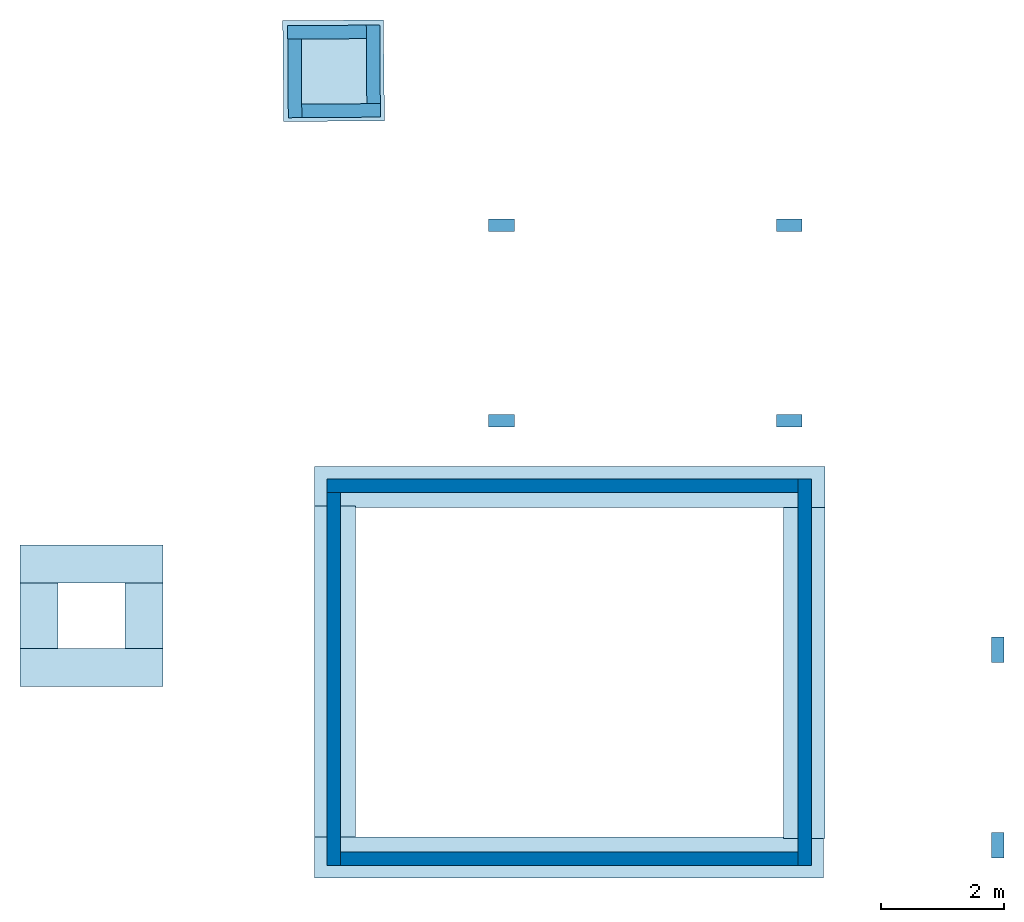
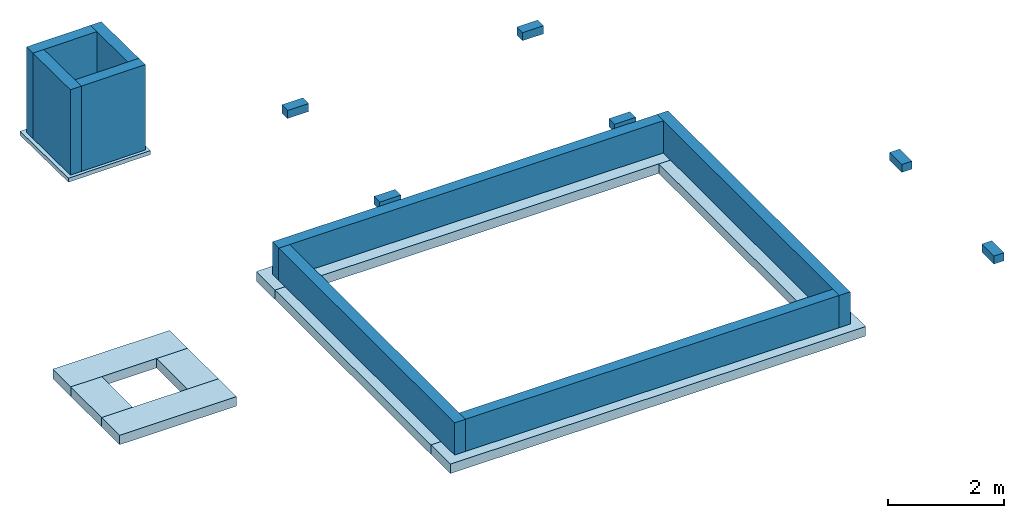
"""IFC4X3_ADD2 building model written with IfcOpenShell, lengths in millimetres."""

import ifcopenshell
import ifcopenshell.guid

model = None  # the IFC model being written
_history = None  # IfcOwnerHistory: only IFC2X3 demands one
_inside = {}  # id of a spatial element -> (the spatial element, [elements in it])
_under = {}  # id of a project, library or spatial element -> (it, [spatial elements below it])
_declared = {}  # id of a project -> (the project, [libraries it declares])
_typed = {}  # id of a type object -> (the type object, [elements of that type])
_made_of = {}  # id of a material, layer set ... -> (it, [elements and type objects made of it])


def new_model(schema):
    """Start an empty IFC model of exactly this schema.

    Asked for "IFC4X3", IfcOpenShell would pick the latest addendum, in which some entities
    have other attributes; the version numbers below select the first issue.
    IFC2X3 requires an IfcOwnerHistory on every rooted entity: one is made here for all.
    """
    global model, _history
    if schema == "IFC4X3":
        model = ifcopenshell.file(schema_version=(4, 3, 0, 0))
    else:
        model = ifcopenshell.file(schema=schema)
    _inside.clear()
    _under.clear()
    _declared.clear()
    _typed.clear()
    _made_of.clear()
    _history = None
    if model.schema == "IFC2X3":
        org = make("IfcOrganization", Name="unknown")
        user = make(
            "IfcPersonAndOrganization",
            ThePerson=make("IfcPerson", FamilyName="unknown"),
            TheOrganization=org,
        )
        app = make(
            "IfcApplication",
            ApplicationDeveloper=org,
            Version="unknown",
            ApplicationFullName="unknown",
            ApplicationIdentifier="unknown",
        )
        _history = make(
            "IfcOwnerHistory",
            OwningUser=user,
            OwningApplication=app,
            ChangeAction="ADDED",
            CreationDate=0,
        )
    return model


def make(cls, **values):
    """One entity of the class cls with the attributes given. An attribute that is None is left unset."""
    return model.create_entity(
        cls, **{name: value for name, value in values.items() if value is not None}
    )


def entity(cls, *values):
    """Any entity or typed value of the class cls, its attributes in the order of the schema. None: left unset."""
    e = model.create_entity(cls)
    for i, value in enumerate(values):
        if value is not None:
            e[i] = value
    return e


def rooted(cls, **values):
    """An entity with a GlobalId (a new one), such as an element, a storey or a relation."""
    return make(cls, GlobalId=ifcopenshell.guid.new(), OwnerHistory=_history, **values)


def si_unit(unit_type, name, prefix=None):
    """IfcSIUnit, for example si_unit("LENGTHUNIT", "METRE", prefix="MILLI")."""
    return make("IfcSIUnit", UnitType=unit_type, Prefix=prefix, Name=name)


def converted_unit(unit_type, name, factor, base, dimensions=None, offset=None):
    """IfcConversionBasedUnit, such as the inch: factor (a typed value) times the base unit."""
    return make(
        "IfcConversionBasedUnit"
        if offset is None
        else "IfcConversionBasedUnitWithOffset",
        ConversionOffset=offset,
        Dimensions=None
        if dimensions is None
        else entity("IfcDimensionalExponents", *dimensions),
        UnitType=unit_type,
        Name=name,
        ConversionFactor=make(
            "IfcMeasureWithUnit", ValueComponent=factor, UnitComponent=base
        ),
    )


def assignment(units):
    """IfcUnitAssignment: the units of a project."""
    return None if units is None else make("IfcUnitAssignment", Units=units)


def point(xyz):
    """IfcCartesianPoint."""
    return None if xyz is None else make("IfcCartesianPoint", Coordinates=xyz)


def direction(xyz):
    """IfcDirection."""
    return None if xyz is None else make("IfcDirection", DirectionRatios=xyz)


def frame(location, z_axis=None, x_axis=None):
    """IfcAxis2Placement3D, a coordinate frame: its origin and axes. An axis left out is left unset."""
    return make(
        "IfcAxis2Placement3D",
        Location=point(location),
        Axis=direction(z_axis),
        RefDirection=direction(x_axis),
    )


def frame_2d(location, x_axis=None):
    """IfcAxis2Placement2D, a coordinate frame in the plane: its origin and x axis."""
    return make(
        "IfcAxis2Placement2D", Location=point(location), RefDirection=direction(x_axis)
    )


def origin_with_axes():
    """The frame at (0, 0, 0) with the z axis (0, 0, 1) and the x axis (1, 0, 0) written out."""
    return frame((0.0, 0.0, 0.0), z_axis=(0.0, 0.0, 1.0), x_axis=(1.0, 0.0, 0.0))


def origin_2d_with_axis():
    """The frame at (0, 0) in the plane with the x axis (1, 0) written out."""
    return frame_2d((0.0, 0.0), x_axis=(1.0, 0.0))


def place(relative_to, where):
    """IfcLocalPlacement: puts the frame where relative to a parent placement (None: the world)."""
    return make(
        "IfcLocalPlacement", PlacementRelTo=relative_to, RelativePlacement=where
    )


def context(
    kind, dimensions, precision=None, world=None, true_north=None, identifier=None
):
    """IfcGeometricRepresentationContext, for example the 3D "Model" context."""
    return make(
        "IfcGeometricRepresentationContext",
        ContextIdentifier=identifier,
        ContextType=kind,
        CoordinateSpaceDimension=dimensions,
        Precision=precision,
        WorldCoordinateSystem=world,
        TrueNorth=true_north,
    )


def subcontext(parent, identifier, kind, view, scale=None):
    """IfcGeometricRepresentationSubContext, for example "Body" below "Model"."""
    return make(
        "IfcGeometricRepresentationSubContext",
        ContextIdentifier=identifier,
        ContextType=kind,
        ParentContext=parent,
        TargetScale=scale,
        TargetView=view,
    )


def project(units=None, contexts=None):
    """IfcProject with its units and contexts."""
    return rooted(
        "IfcProject",
        Name="project",
        RepresentationContexts=contexts,
        UnitsInContext=assignment(units),
    )


def spatial(cls, under=None, at=None, **own):
    """A site, building, storey or space (cls), placed at a placement, below another one or the project."""
    s = rooted(cls, ObjectPlacement=at, **own)
    if under is not None:
        _under.setdefault(under.id(), (under, []))[1].append(s)
    return s


def point_list(points):
    """IfcCartesianPointList2D or 3D."""
    cls = (
        "IfcCartesianPointList2D" if len(points[0]) == 2 else "IfcCartesianPointList3D"
    )
    return make(cls, CoordList=points)


def indexed_curve(points, segments=None, self_intersect=None):
    """IfcIndexedPolyCurve: lines and arcs through numbered points (the first is 1)."""
    return make(
        "IfcIndexedPolyCurve",
        Points=point_list(points),
        Segments=segments,
        SelfIntersect=self_intersect,
    )


def outline(outer, holes=None, kind="AREA"):
    """IfcArbitraryClosedProfileDef: a profile drawn as a closed curve; with holes, ...WithVoids."""
    if holes is None:
        return make("IfcArbitraryClosedProfileDef", ProfileType=kind, OuterCurve=outer)
    return make(
        "IfcArbitraryProfileDefWithVoids",
        ProfileType=kind,
        OuterCurve=outer,
        InnerCurves=holes,
    )


def extrude(swept, where, along, depth):
    """IfcExtrudedAreaSolid: the profile swept, set in the frame where, extruded along a direction by depth."""
    return make(
        "IfcExtrudedAreaSolid",
        SweptArea=swept,
        Position=where,
        ExtrudedDirection=direction(along),
        Depth=depth,
    )


def shape(context_of_items, identifier, shape_type, items):
    """IfcShapeRepresentation: the items that make up one representation, for example the "Body"."""
    return make(
        "IfcShapeRepresentation",
        ContextOfItems=context_of_items,
        RepresentationIdentifier=identifier,
        RepresentationType=shape_type,
        Items=items,
    )


def material(Name=None, Category=None):
    """IfcMaterial."""
    return make("IfcMaterial", Name=Name, Category=Category)


def layer(
    of_material, thickness, ventilated=None, Name=None, Category=None, Priority=None
):
    """IfcMaterialLayer: one layer of a wall or slab, of a material (None: an air gap)."""
    return make(
        "IfcMaterialLayer",
        Material=of_material,
        LayerThickness=thickness,
        IsVentilated=ventilated,
        Name=Name,
        Category=Category,
        Priority=Priority,
    )


def layer_set(layers, Name=None):
    """IfcMaterialLayerSet."""
    return make("IfcMaterialLayerSet", MaterialLayers=layers, LayerSetName=Name)


def layer_usage(for_layer_set, set_direction, sense, offset, extent=None):
    """IfcMaterialLayerSetUsage: how a layer set lies in its element."""
    return make(
        "IfcMaterialLayerSetUsage",
        ForLayerSet=for_layer_set,
        LayerSetDirection=set_direction,
        DirectionSense=sense,
        OffsetFromReferenceLine=offset,
        ReferenceExtent=extent,
    )


def made_of(thing, what):
    """Note that an element or type object is made of a material, layer set ...; save() writes the relation."""
    if what is not None:
        _made_of.setdefault(what.id(), (what, []))[1].append(thing)
    return thing


def type_object(cls, material=None, **own):
    """A type object (cls), such as IfcWallType, which elements share."""
    return made_of(rooted(cls, **own), material)


def element(
    cls,
    number,
    at=None,
    inside=None,
    cuts=None,
    type_object=None,
    material=None,
    context=None,
    identifier="Body",
    shape_type=None,
    held_by="IfcProductDefinitionShape",
    body=None,
    shapes=None,
    **own,
):
    """One element of the class cls, such as IfcWall. Its Tag is "e" and its number.

    at: its placement. inside: the storey or other place that contains it. cuts: it is an
    opening in that element (IfcRelVoidsElement). A single representation is given by context,
    identifier, shape_type and body (its items); several are given by shapes. held_by: the class
    of the entity that holds the representations. save() writes the other relations.
    """
    e = rooted(cls, Tag="e%d" % number, ObjectPlacement=at, **own)
    if body is not None:
        shapes = [shape(context, identifier, shape_type, body)]
    if shapes is not None:
        e.Representation = make(held_by, Representations=shapes)
    if inside is not None:
        _inside.setdefault(inside.id(), (inside, []))[1].append(e)
    if cuts is not None:
        rooted(
            "IfcRelVoidsElement", RelatingBuildingElement=cuts, RelatedOpeningElement=e
        )
    if type_object is not None:
        _typed.setdefault(type_object.id(), (type_object, []))[1].append(e)
    return made_of(e, material)


def aggregate(whole, parts):
    """IfcRelAggregates: a whole, such as a stair, and the parts it consists of."""
    return rooted("IfcRelAggregates", RelatingObject=whole, RelatedObjects=parts)


def save(model, path):
    """Write the relations noted so far, then the file.

    IfcRelAggregates (storeys below a building ...), IfcRelContainedInSpatialStructure (elements
    in a storey), IfcRelDefinesByType, IfcRelAssociatesMaterial and IfcRelDeclares: one each for
    every whole, place, type object, material and project.
    """
    for whole, parts in _under.values():
        aggregate(whole, parts)
    for where, things in _inside.values():
        rooted(
            "IfcRelContainedInSpatialStructure",
            RelatedElements=things,
            RelatingStructure=where,
        )
    for kind, things in _typed.values():
        rooted("IfcRelDefinesByType", RelatedObjects=things, RelatingType=kind)
    for what, things in _made_of.values():
        rooted("IfcRelAssociatesMaterial", RelatedObjects=things, RelatingMaterial=what)
    for by, libraries in _declared.values():
        rooted("IfcRelDeclares", RelatingContext=by, RelatedDefinitions=libraries)
    model.write(path)


model = new_model("IFC4X3_ADD2")

# Units and contexts
model_context = context("Model", 3, precision=1e-05, world=origin_with_axes(), true_north=direction((0.0, 1.0, 0.0)))
plan_context = context("Plan", 2, precision=1e-05, world=origin_2d_with_axis(), true_north=direction((0.0, 1.0)))
body_context = subcontext(model_context, "Body", "Model", "MODEL_VIEW")
ifc_project = project(units=[si_unit("AREAUNIT", "SQUARE_METRE"), si_unit("VOLUMEUNIT", "CUBIC_METRE"), si_unit("LENGTHUNIT", "METRE", prefix="MILLI"), converted_unit("PLANEANGLEUNIT", "degree", entity("IfcReal", 0.0174532925199433), si_unit("PLANEANGLEUNIT", "RADIAN"), dimensions=[0, 0, 0, 0, 0, 0, 0])], contexts=[model_context, plan_context])

# Site, building, storeys
site_placement = place(None, origin_with_axes())
site = spatial("IfcSite", under=ifc_project, at=site_placement)
building_placement = place(site_placement, origin_with_axes())
building = spatial("IfcBuilding", under=site, at=building_placement, Name="Simple 1Bed House")
storey_1_placement = place(building_placement, origin_with_axes())
storey_1 = spatial("IfcBuildingStorey", under=building, at=storey_1_placement, Name="Building")
storey_2_placement = place(storey_1_placement, origin_with_axes())
storey_2 = spatial("IfcBuildingStorey", under=storey_1, at=storey_2_placement, Name="Foundation")

# Footings
ifc_material_1 = material(Name="25 MPa wooden float", Category="Concrete")
ifc_layer_1 = layer(ifc_material_1, 200.0)
ifc_layer_set_1 = layer_set([ifc_layer_1], Name="concrete")
ifc_layer_usage_1 = layer_usage(ifc_layer_set_1, "AXIS3", "POSITIVE", 0.0)
footing_type = type_object("IfcFootingType", Name="Foundation 600x280", PredefinedType="STRIP_FOOTING", material=ifc_layer_set_1)
footing_1_placement = place(storey_2_placement, frame((8640.92254638672, 6085.35528182983, -879.999995231629), z_axis=(0.0, 0.0, 1.0), x_axis=(-0.999999999999924, -3.89414367418765e-07, 0.0)))
element("IfcFooting", 1, at=footing_1_placement, inside=storey_2, type_object=footing_type, material=ifc_layer_usage_1, Name="600x280 Concrete foundation", context=body_context, shape_type="SolidModel", body=[
    extrude(outline(indexed_curve([(8369.2353515625, -445.002777099609), (59.7821655273438, -445.002777099609), (59.7821807861328, 224.999267578125), (8369.2353515625, 224.999252319336), (8369.2353515625, -445.002777099609)])), None, (0.0, 0.0, 1.0), 200.0),
])
ifc_layer_usage_2 = layer_usage(ifc_layer_set_1, "AXIS3", "POSITIVE", 0.0)
footing_2_placement = place(storey_2_placement, frame((716.687917709351, 6435.35232543945, -879.999995231628), z_axis=(0.0, 0.0, 1.0), x_axis=(-0.999999999999924, -3.89414367418765e-07, 0.0)))
element("IfcFooting", 2, at=footing_2_placement, inside=storey_2, type_object=footing_type, material=ifc_layer_usage_2, Name="600x280 Concrete foundation", context=body_context, shape_type="SolidModel", body=[
    extrude(outline(indexed_curve([(445.001586914062, 5934.35107421875), (445.001525878906, 549.999328613281), (-224.999923706055, 549.999328613281), (-224.999786376953, 5934.35107421875), (445.001586914062, 5934.35107421875)])), None, (0.0, 0.0, 1.0), 200.0),
])
ifc_layer_usage_3 = layer_usage(ifc_layer_set_1, "AXIS3", "POSITIVE", 0.0)
footing_3_placement = place(storey_2_placement, frame((8640.92445373535, 56.000292301178, -879.999995231628), z_axis=(0.0, 0.0, 1.0), x_axis=(-0.999999999999924, -3.89414367418765e-07, 0.0)))
element("IfcFooting", 3, at=footing_3_placement, inside=storey_2, type_object=footing_type, material=ifc_layer_usage_3, Name="600x280 Concrete foundation", context=body_context, shape_type="SolidModel", body=[
    extrude(outline(indexed_curve([(84.7802658081055, -445.002777099609), (84.7802810668945, 224.999252319336), (8369.234375, 224.999252319336), (8369.234375, -445.002777099609), (84.7802658081055, -445.002777099609)])), None, (0.0, 0.0, 1.0), 200.0),
])
ifc_layer_usage_4 = layer_usage(ifc_layer_set_1, "AXIS2", "POSITIVE", 0.0)
footing_4_placement = place(storey_2_placement, frame((3104.93040084839, 10359.0650558472, -769.999980926514), z_axis=(0.0, 0.0, 1.0), x_axis=(0.999999999999936, -3.57627868652321e-07, 0.0)))
element("IfcFooting", 4, at=footing_4_placement, inside=storey_2, type_object=footing_type, material=ifc_layer_usage_4, Name="Footing", context=body_context, shape_type="SweptSolid", body=[
    extrude(outline(indexed_curve([(0.0, 0.0), (0.0, 200.0), (420.001035813916, 200.0), (420.001035813916, 0.0), (0.0, 0.0)], self_intersect=False)), origin_with_axes(), (0.0, 0.0, 1.0), 170.000001788139),
])
ifc_layer_usage_5 = layer_usage(ifc_layer_set_1, "AXIS2", "POSITIVE", 0.0)
footing_5_placement = place(storey_2_placement, frame((11500.0066757202, 3335.84809303284, -516.634404659271), z_axis=(0.0, 0.0, 1.0), x_axis=(3.13916473260163e-07, 0.999999999999951, 0.0)))
element("IfcFooting", 5, at=footing_5_placement, inside=storey_2, type_object=footing_type, material=ifc_layer_usage_5, Name="Footing", context=body_context, shape_type="SweptSolid", body=[
    extrude(outline(indexed_curve([(0.0, 0.0), (0.0, 200.0), (420.001035813916, 200.0), (420.001035813916, 0.0), (0.0, 0.0)], self_intersect=False)), origin_with_axes(), (0.0, 0.0, 1.0), 170.000001788139),
])
ifc_layer_usage_6 = layer_usage(ifc_layer_set_1, "AXIS2", "POSITIVE", 0.0)
footing_6_placement = place(storey_2_placement, frame((11500.0076293945, 150.846943259239, -516.634404659271), z_axis=(0.0, 0.0, 1.0), x_axis=(3.13916473260163e-07, 0.999999999999951, 0.0)))
element("IfcFooting", 6, at=footing_6_placement, inside=storey_2, type_object=footing_type, material=ifc_layer_usage_6, Name="Footing", context=body_context, shape_type="SweptSolid", body=[
    extrude(outline(indexed_curve([(0.0, 0.0), (0.0, 200.0), (420.001035813916, 200.0), (420.001035813916, 0.0), (0.0, 0.0)], self_intersect=False)), origin_with_axes(), (0.0, 0.0, 1.0), 170.000001788139),
])
ifc_layer_usage_7 = layer_usage(ifc_layer_set_1, "AXIS2", "POSITIVE", 0.0)
footing_7_placement = place(storey_2_placement, frame((7791.34273529053, 10359.0650558472, -769.999921321869), z_axis=(0.0, 0.0, 1.0), x_axis=(0.999999999999936, -3.57627868652321e-07, 0.0)))
element("IfcFooting", 7, at=footing_7_placement, inside=storey_2, type_object=footing_type, material=ifc_layer_usage_7, Name="Footing", context=body_context, shape_type="SweptSolid", body=[
    extrude(outline(indexed_curve([(0.0, 0.0), (0.0, 200.0), (420.001035813916, 200.0), (420.001035813916, 0.0), (0.0, 0.0)], self_intersect=False)), origin_with_axes(), (0.0, 0.0, 1.0), 170.000001788139),
])
ifc_layer_usage_8 = layer_usage(ifc_layer_set_1, "AXIS3", "POSITIVE", 0.0)
footing_8_placement = place(storey_2_placement, frame((8356.14013671875, 6435.35232543945, -879.999995231628), z_axis=(0.0, 0.0, 1.0), x_axis=(-0.999999999999924, -3.89414367418765e-07, 0.0)))
element("IfcFooting", 8, at=footing_8_placement, inside=storey_2, type_object=footing_type, material=ifc_layer_usage_8, Name="600x280 Concrete foundation", context=body_context, shape_type="SolidModel", body=[
    extrude(outline(indexed_curve([(445.001617431641, 5959.3486328125), (445.001525878906, 574.999267578125), (-224.999908447266, 574.999267578125), (-224.999771118164, 5959.3486328125), (445.001617431641, 5959.3486328125)])), None, (0.0, 0.0, 1.0), 200.0),
])
ifc_layer_usage_9 = layer_usage(ifc_layer_set_1, "AXIS3", "POSITIVE", 0.0)
footing_9_placement = place(storey_2_placement, frame((3718.46485137939, 4830.3394317627, -481.297969818115), z_axis=(0.0, 0.0, 1.0), x_axis=(-0.999999999999924, -3.89414367418765e-07, 0.0)))
element("IfcFooting", 9, at=footing_9_placement, inside=storey_2, type_object=footing_type, material=ifc_layer_usage_9, Name="600x280 Concrete foundation", context=body_context, shape_type="SweptSolid", body=[
    extrude(outline(indexed_curve([(8245.234375, 199.99934387207), (5915.3359375, 199.996994018555), (5915.3359375, -420.005126953125), (8245.234375, -420.002807617188), (8245.234375, 199.99934387207)])), None, (0.0, 0.0, 1.0), 200.0),
])
ifc_layer_usage_10 = layer_usage(ifc_layer_set_1, "AXIS3", "POSITIVE", 0.0)
footing_10_placement = place(storey_2_placement, frame((3718.46485137939, 3145.9321975708, -481.297969818115), z_axis=(0.0, 0.0, 1.0), x_axis=(-0.999999999999924, -3.89414367418765e-07, 0.0)))
element("IfcFooting", 10, at=footing_10_placement, inside=storey_2, type_object=footing_type, material=ifc_layer_usage_10, Name="600x280 Concrete foundation", context=body_context, shape_type="SweptSolid", body=[
    extrude(outline(indexed_curve([(8245.234375, 199.99934387207), (5915.3359375, 199.996994018555), (5915.3359375, -420.005126953125), (8245.234375, -420.002807617188), (8245.234375, 199.99934387207)])), None, (0.0, 0.0, 1.0), 200.0),
])
ifc_layer_usage_11 = layer_usage(ifc_layer_set_1, "AXIS3", "POSITIVE", 0.0)
footing_11_placement = place(storey_2_placement, frame((-4106.76670074463, 10545.6762313843, -481.297969818115), z_axis=(0.0, 0.0, 1.0), x_axis=(5.52335052361657e-07, -0.999999999999847, 0.0)))
element("IfcFooting", 11, at=footing_11_placement, inside=storey_2, type_object=footing_type, material=ifc_layer_usage_11, Name="600x280 Concrete foundation", context=body_context, shape_type="SweptSolid", body=[
    extrude(outline(indexed_curve([(6979.74462890625, -420.002258300781), (6979.74462890625, 199.999893188477), (5915.3359375, 199.996978759766), (5915.3359375, -420.005096435547), (6979.74462890625, -420.002258300781)])), None, (0.0, 0.0, 1.0), 200.0),
])
ifc_layer_usage_12 = layer_usage(ifc_layer_set_1, "AXIS3", "POSITIVE", 0.0)
footing_12_placement = place(storey_2_placement, frame((-2396.87347412109, 10545.6762313843, -481.297969818115), z_axis=(0.0, 0.0, 1.0), x_axis=(5.52335052361657e-07, -0.999999999999847, 0.0)))
element("IfcFooting", 12, at=footing_12_placement, inside=storey_2, type_object=footing_type, material=ifc_layer_usage_12, Name="600x280 Concrete foundation", context=body_context, shape_type="SweptSolid", body=[
    extrude(outline(indexed_curve([(6979.74462890625, -420.002258300781), (6979.74462890625, 199.999893188477), (5915.3359375, 199.996978759766), (5915.3359375, -420.005096435547), (6979.74462890625, -420.002258300781)])), None, (0.0, 0.0, 1.0), 200.0),
])
ifc_layer_usage_13 = layer_usage(ifc_layer_set_1, "AXIS2", "POSITIVE", 0.0)
footing_13_placement = place(storey_2_placement, frame((7791.34273529053, 7175.35209655762, -769.999921321869), z_axis=(0.0, 0.0, 1.0), x_axis=(0.999999999999936, -3.57627868652321e-07, 0.0)))
element("IfcFooting", 13, at=footing_13_placement, inside=storey_2, type_object=footing_type, material=ifc_layer_usage_13, Name="Footing", context=body_context, shape_type="SweptSolid", body=[
    extrude(outline(indexed_curve([(0.0, 0.0), (0.0, 200.0), (420.001035813916, 200.0), (420.001035813916, 0.0), (0.0, 0.0)], self_intersect=False)), origin_with_axes(), (0.0, 0.0, 1.0), 170.000001788139),
])
ifc_layer_usage_14 = layer_usage(ifc_layer_set_1, "AXIS2", "POSITIVE", 0.0)
footing_14_placement = place(storey_2_placement, frame((3104.93040084839, 7175.35209655762, -769.999980926514), z_axis=(0.0, 0.0, 1.0), x_axis=(0.999999999999936, -3.57627868652321e-07, 0.0)))
element("IfcFooting", 14, at=footing_14_placement, inside=storey_2, type_object=footing_type, material=ifc_layer_usage_14, Name="Footing", context=body_context, shape_type="SweptSolid", body=[
    extrude(outline(indexed_curve([(0.0, 0.0), (0.0, 200.0), (420.001035813916, 200.0), (420.001035813916, 0.0), (0.0, 0.0)], self_intersect=False)), origin_with_axes(), (0.0, 0.0, 1.0), 170.000001788139),
])

# Slab
ifc_layer_2 = layer(ifc_material_1, 85.0)
ifc_layer_set_2 = layer_set([ifc_layer_2], Name="concrete")
ifc_layer_usage_15 = layer_usage(ifc_layer_set_2, "AXIS3", "POSITIVE", 0.0)
slab_type = type_object("IfcSlabType", Name="85mm surface bed", PredefinedType="BASESLAB", material=ifc_layer_set_2)
slab_placement = place(storey_2_placement, frame((1114.15302753448, 13500.3852844238, -2029.48331832886), z_axis=(0.0, 0.0, 1.0), x_axis=(-0.6593312610676, -0.751852570773691, 0.0)))
element("IfcSlab", 15, at=slab_placement, inside=storey_2, type_object=slab_type, material=ifc_layer_usage_15, Name="Slab", context=body_context, shape_type="SweptSolid", body=[
    extrude(outline(indexed_curve([(-410.597381591797, 8.12553310394287), (810.0556640625, 1105.19006347656), (1904.17846679688, -120.903175354004), (678.37841796875, -1217.9677734375), (-410.597381591797, 8.12553310394287)])), None, (0.0, 0.0, 1.0), 85.0),
])

# Walls
ifc_material_2 = material(Name="NFX-Clay", Category="Clay Bricks")
ifc_layer_3 = layer(ifc_material_2, 220.0, Name="hg")
ifc_layer_set_3 = layer_set([ifc_layer_3], Name="brick")
ifc_layer_usage_16 = layer_usage(ifc_layer_set_3, "AXIS2", "POSITIVE", 0.0)
wall_type = type_object("IfcWallType", Name="220mm foundation", PredefinedType="ELEMENTEDWALL", material=ifc_layer_set_3)
wall_1_placement = place(storey_2_placement, frame((472.80889749527, 6105.99327087402, -680.000007152557), z_axis=(0.0, 0.0, 1.0), x_axis=(1.5060094256097e-06, -0.999999999998866, 0.0)))
element("IfcWall", 16, at=wall_1_placement, inside=storey_2, type_object=wall_type, material=ifc_layer_usage_16, Name="220mm Foundation", context=body_context, shape_type="SweptSolid", body=[
    extrude(outline(indexed_curve([(0.0, 0.0), (0.0, 220.0), (6074.99994977219, 220.0), (6074.99994977219, 0.0), (0.0, 0.0)], self_intersect=False)), origin_with_axes(), (0.0, 0.0, 1.0), 680.000007152557),
])
ifc_layer_usage_17 = layer_usage(ifc_layer_set_3, "AXIS2", "POSITIVE", 0.0)
wall_2_placement = place(storey_2_placement, frame((472.80889749527, 6105.99327087402, -680.000007152557), z_axis=(0.0, 0.0, 1.0), x_axis=(0.999999999999545, 9.53674316405816e-07, 0.0)))
element("IfcWall", 17, at=wall_2_placement, inside=storey_2, type_object=wall_type, material=ifc_layer_usage_17, Name="220mm Foundation", context=body_context, shape_type="SweptSolid", body=[
    extrude(outline(indexed_curve([(0.0, 0.0), (0.0, 220.0), (7671.63284448229, 220.0), (7671.63284448229, 0.0), (0.0, 0.0)], self_intersect=False)), origin_with_axes(), (0.0, 0.0, 1.0), 680.000007152557),
])
ifc_layer_usage_18 = layer_usage(ifc_layer_set_3, "AXIS2", "POSITIVE", 0.0)
wall_3_placement = place(storey_2_placement, frame((692.817986011505, 30.9935659170151, -680.000007152557), z_axis=(0.0, 0.0, 1.0), x_axis=(0.999999999999545, 9.53674316405816e-07, 0.0)))
element("IfcWall", 18, at=wall_3_placement, inside=storey_2, type_object=wall_type, material=ifc_layer_usage_18, Name="220mm Foundation", context=body_context, shape_type="SweptSolid", body=[
    extrude(outline(indexed_curve([(0.0, 0.0), (0.0, 220.0), (7451.63288015566, 220.0), (7451.63288015566, 0.0), (0.0, 0.0)], self_intersect=False)), origin_with_axes(), (0.0, 0.0, 1.0), 680.000007152557),
])
ifc_layer_usage_19 = layer_usage(ifc_layer_set_3, "AXIS2", "POSITIVE", 0.0)
wall_4_placement = place(storey_2_placement, frame((8144.44255828857, 6326.00021362305, -680.000007152557), z_axis=(0.0, 0.0, 1.0), x_axis=(1.5060094256097e-06, -0.999999999998866, 0.0)))
element("IfcWall", 19, at=wall_4_placement, inside=storey_2, type_object=wall_type, material=ifc_layer_usage_19, Name="220mm Foundation", context=body_context, shape_type="SweptSolid", body=[
    extrude(outline(indexed_curve([(0.0, 0.0), (0.0, 220.0), (6294.99913901878, 220.0), (6294.99913901878, 0.0), (0.0, 0.0)], self_intersect=False)), origin_with_axes(), (0.0, 0.0, 1.0), 680.000007152557),
])
ifc_layer_usage_20 = layer_usage(ifc_layer_set_3, "AXIS2", "POSITIVE", 0.0)
wall_5_placement = place(storey_2_placement, frame((1112.57374286652, 13720.3788757324, -1944.48328018188), z_axis=(0.0, 0.0, 1.0), x_axis=(-0.999974250842694, -0.00717618642410207, 0.0)))
element("IfcWall", 20, at=wall_5_placement, inside=storey_2, type_object=wall_type, material=ifc_layer_usage_20, Name="Wall", context=body_context, shape_type="SweptSolid", body=[
    extrude(outline(indexed_curve([(0.0, 0.0), (0.0, 220.0), (1279.99986741691, 220.0), (1279.99986741691, 0.0), (0.0, 0.0)], self_intersect=False)), origin_with_axes(), (0.0, 0.0, 1.0), 1800.00007152557),
])
ifc_layer_usage_21 = layer_usage(ifc_layer_set_3, "AXIS2", "POSITIVE", 0.0)
wall_6_placement = place(storey_2_placement, frame((1341.75229072571, 12441.9898986816, -1944.48328018188), z_axis=(0.0, 0.0, 1.0), x_axis=(-0.00717578551037913, 0.999974253719719, 0.0)))
element("IfcWall", 21, at=wall_6_placement, inside=storey_2, type_object=wall_type, material=ifc_layer_usage_21, Name="Wall", context=body_context, shape_type="SweptSolid", body=[
    extrude(outline(indexed_curve([(0.0, 0.0), (0.0, 220.0), (1280.00119455103, 220.0), (1280.00119455103, 0.0), (0.0, 0.0)], self_intersect=False)), origin_with_axes(), (0.0, 0.0, 1.0), 1800.00007152557),
])
ifc_layer_usage_22 = layer_usage(ifc_layer_set_3, "AXIS2", "POSITIVE", 0.0)
wall_7_placement = place(storey_2_placement, frame((-165.814638137817, 13491.1994934082, -1944.48328018188), z_axis=(0.0, 0.0, 1.0), x_axis=(0.00717587258455618, -0.999974253094874, 0.0)))
element("IfcWall", 22, at=wall_7_placement, inside=storey_2, type_object=wall_type, material=ifc_layer_usage_22, Name="Wall", context=body_context, shape_type="SweptSolid", body=[
    extrude(outline(indexed_curve([(0.0, 0.0), (0.0, 220.0), (1279.99986741691, 220.0), (1279.99986741691, 0.0), (0.0, 0.0)], self_intersect=False)), origin_with_axes(), (0.0, 0.0, 1.0), 1800.00007152557),
])
ifc_layer_usage_23 = layer_usage(ifc_layer_set_3, "AXIS2", "POSITIVE", 0.0)
wall_8_placement = place(storey_2_placement, frame((63.3647441864014, 12212.8124237061, -1944.48328018188), z_axis=(0.0, 0.0, 1.0), x_axis=(0.999974254889196, 0.00717562253732003, 0.0)))
element("IfcWall", 23, at=wall_8_placement, inside=storey_2, type_object=wall_type, material=ifc_layer_usage_23, Name="Wall", context=body_context, shape_type="SweptSolid", body=[
    extrude(outline(indexed_curve([(0.0, 0.0), (0.0, 220.0), (1279.99921549088, 220.0), (1279.99921549088, 0.0), (0.0, 0.0)], self_intersect=False)), origin_with_axes(), (0.0, 0.0, 1.0), 1800.00007152557),
])

save(model, "model.ifc")
